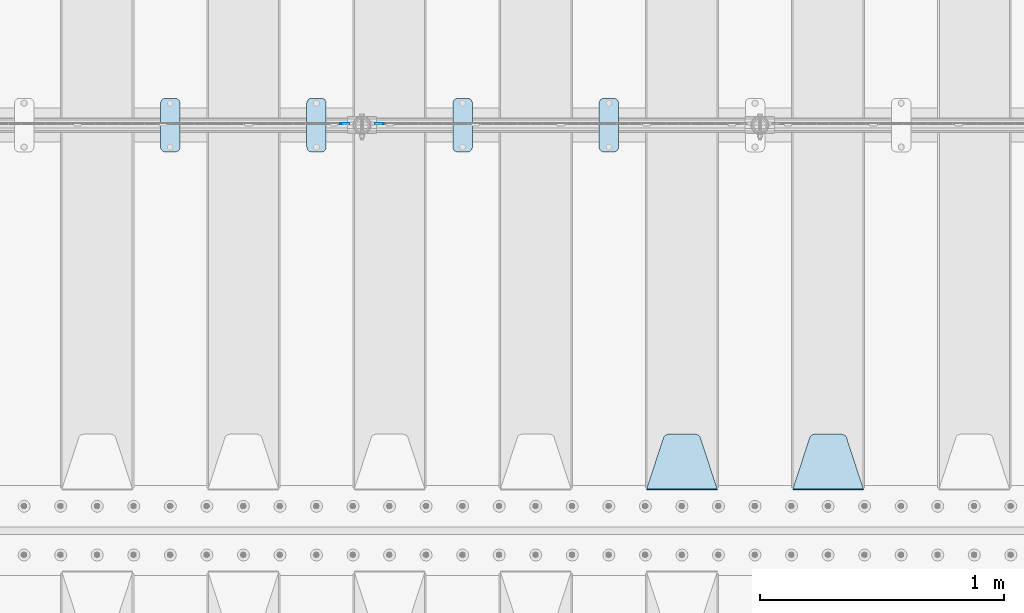
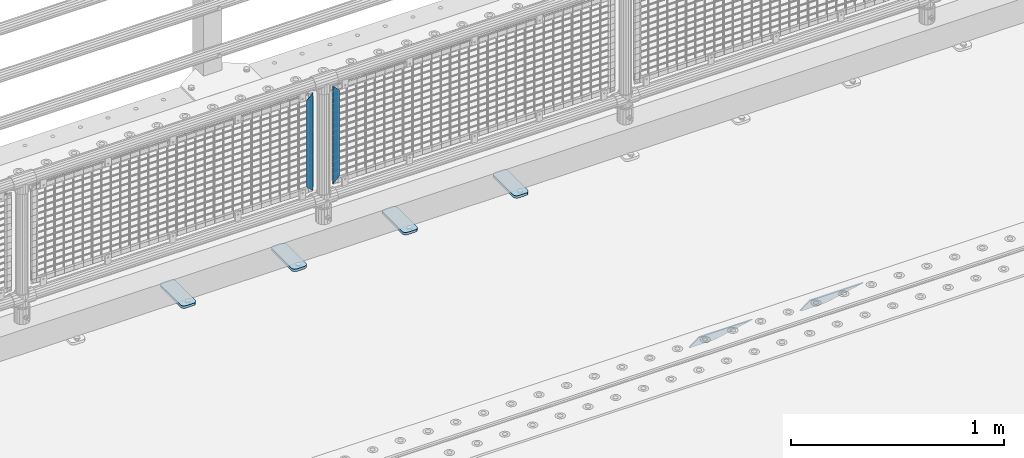
# One storey, part 202 of 242: 8 plates.
"""IFC2X3 building model written with IfcOpenShell, lengths in millimetres."""

from ifc_helpers import new_model, si_unit, frame, origin_with_axes, place, context, subcontext, project, spatial, faceted_brep, material, type_object, element, save


model = new_model("IFC2X3")

# Units and contexts
model_context = context("Model", 3, precision=1e-05, world=origin_with_axes())
body_context = subcontext(model_context, "Body", "Model", "MODEL_VIEW")
ifc_project = project(units=[si_unit("LENGTHUNIT", "METRE", prefix="MILLI"), si_unit("AREAUNIT", "SQUARE_METRE"), si_unit("VOLUMEUNIT", "CUBIC_METRE"), si_unit("MASSUNIT", "GRAM", prefix="KILO"), si_unit("TIMEUNIT", "SECOND"), si_unit("PLANEANGLEUNIT", "RADIAN"), si_unit("SOLIDANGLEUNIT", "STERADIAN"), si_unit("THERMODYNAMICTEMPERATUREUNIT", "DEGREE_CELSIUS"), si_unit("LUMINOUSINTENSITYUNIT", "LUMEN")], contexts=[model_context])

# Site, building, storey
site_placement = place(None, origin_with_axes())
site = spatial("IfcSite", under=ifc_project, at=site_placement, CompositionType="ELEMENT")
building_placement = place(site_placement, origin_with_axes())
building = spatial("IfcBuilding", under=site, at=building_placement, Name="Standard", CompositionType="ELEMENT")
storey_placement = place(building_placement, origin_with_axes())
storey = spatial("IfcBuildingStorey", under=building, at=storey_placement, Name="Undefined", CompositionType="ELEMENT", Elevation=0.0)

# Plates
ifc_material_1 = material(Name="Misc_Undefined")
plate_type_1 = type_object("IfcPlateType", PredefinedType="NOTDEFINED")
plate_1_placement = place(storey_placement, frame((-38474.490286459, -19329.5, 879.519963133601), z_axis=(-0.707008801899319, 0.0, -0.707204746899291), x_axis=(-0.707204746899296, 0.0, 0.707008801899313)))
element("IfcPlate", 1, at=plate_1_placement, inside=storey, type_object=plate_type_1, material=ifc_material_1, context=body_context, shape_type="Brep", body=[
    faceted_brep([(0.0, -1.50000000000364, 0.0), (-348.552185058597, -1.5, 348.655029296875), (-348.552185058597, 1.5, 348.655029296875), (-3.63797880709171e-12, 1.49999999999636, 0.0), (-348.544891357426, -1.5, 398.152496337891), (-348.544891357426, 1.5, 398.152496337891), (49.5043945312464, -1.5, 8.00355337560177e-11), (49.5043945312464, 1.5, 8.00355337560177e-11)], [[[0, 1, 2, 3]], [[1, 4, 5, 2]], [[4, 6, 7, 5]], [[6, 0, 3, 7]], [[5, 7, 3, 2]], [[6, 4, 1, 0]]]),
])
plate_2_placement = place(storey_placement, frame((-38651.5003125164, -19329.5, 879.52), z_axis=(0.707103624179499, 0.0, -0.707109938179501), x_axis=(0.707109938179508, 0.0, 0.707103624179492)))
element("IfcPlate", 2, at=plate_2_placement, inside=storey, type_object=plate_type_1, material=ifc_material_1, context=body_context, shape_type="Brep", body=[
    faceted_brep([(0.0, -1.50000000000364, 0.0), (-348.605163574222, -1.5, 348.602081298832), (-348.605163574222, 1.5, 348.602081298832), (-3.63797880709171e-12, 1.49999999999636, 0.0), (-348.605163574222, -1.5, 398.099334716801), (-348.605163574222, 1.5, 398.099334716801), (49.4976959228534, -1.5, -3.63797880709171e-12), (49.4976959228534, 1.5, -3.63797880709171e-12)], [[[0, 1, 2, 3]], [[1, 4, 5, 2]], [[4, 6, 7, 5]], [[6, 0, 3, 7]], [[5, 7, 3, 2]], [[6, 4, 1, 0]]]),
])
ifc_material_2 = material(Name="STEEL/S355J2")
plate_type_2 = type_object("IfcPlateType", PredefinedType="NOTDEFINED")
plate_3_placement = place(storey_placement, frame((-37590.0, -19225.5, 21.0199999999977), z_axis=(1.0, 0.0, 0.0), x_axis=(0.0, -1.0, 0.0)))
element("IfcPlate", 3, at=plate_3_placement, inside=storey, type_object=plate_type_2, material=ifc_material_2, context=body_context, shape_type="Brep", body=[
    faceted_brep([(0.0, -7.0, 20.0), (0.0, -7.0, 60.0), (0.0, 7.0, 60.0), (0.0, 7.0, 20.0), (0.384294391937146, -7.0, 63.9018064403208), (0.384294391937146, 7.0, 63.9018064403208), (1.52240934977453, -7.0, 67.6536686473009), (1.52240934977453, 7.0, 67.6536686473009), (3.37060775395003, -7.0, 71.1114046603907), (3.37060775395003, 7.0, 71.1114046603907), (5.8578643762703, -7.0, 74.1421356237297), (5.8578643762703, 7.0, 74.1421356237297), (8.88859533960931, -7.0, 76.62939224605), (8.88859533960931, 7.0, 76.62939224605), (12.3463313526991, -7.0, 78.4775906502255), (12.3463313526991, 7.0, 78.4775906502255), (16.0981935596792, -7.0, 79.6157056080629), (16.0981935596792, 7.0, 79.6157056080629), (20.0, -7.0, 80.0), (20.0, 7.0, 80.0), (200.0, -7.0, 80.0), (200.0, 7.0, 80.0), (203.901806440321, -7.0, 79.6157056080629), (203.901806440321, 7.0, 79.6157056080629), (207.653668647301, -7.0, 78.4775906502255), (207.653668647301, 7.0, 78.4775906502255), (211.111404660391, -7.0, 76.62939224605), (211.111404660391, 7.0, 76.62939224605), (214.14213562373, -7.0, 74.1421356237297), (214.14213562373, 7.0, 74.1421356237297), (216.62939224605, -7.0, 71.1114046603907), (216.62939224605, 7.0, 71.1114046603907), (218.477590650225, -7.0, 67.6536686473009), (218.477590650225, 7.0, 67.6536686473009), (219.615705608063, -7.0, 63.9018064403208), (219.615705608063, 7.0, 63.9018064403208), (220.0, -7.0, 60.0), (220.0, 7.0, 60.0), (220.0, -7.0, 20.0), (220.0, 7.0, 20.0), (219.615705608063, -7.0, 16.0981935596792), (219.615705608063, 7.0, 16.0981935596792), (218.477590650225, -7.0, 12.3463313526991), (218.477590650225, 7.0, 12.3463313526991), (216.62939224605, -7.0, 8.88859533960931), (216.62939224605, 7.0, 8.88859533960931), (214.14213562373, -7.0, 5.8578643762703), (214.14213562373, 7.0, 5.8578643762703), (211.111404660391, -7.0, 3.37060775395003), (211.111404660391, 7.0, 3.37060775395003), (207.653668647301, -7.0, 1.52240934977453), (207.653668647301, 7.0, 1.52240934977453), (203.901806440321, -7.0, 0.384294391937146), (203.901806440321, 7.0, 0.384294391937146), (200.0, -7.0, 0.0), (200.0, 7.0, 0.0), (20.0, -7.0, 0.0), (20.0, 7.0, 0.0), (16.0981935596792, -7.0, 0.384294391937146), (16.0981935596792, 7.0, 0.384294391937146), (12.3463313526991, -7.0, 1.52240934977453), (12.3463313526991, 7.0, 1.52240934977453), (8.88859533960931, -7.0, 3.37060775395003), (8.88859533960931, 7.0, 3.37060775395003), (5.8578643762703, -7.0, 5.8578643762703), (5.8578643762703, 7.0, 5.8578643762703), (3.37060775395003, -7.0, 8.88859533960931), (3.37060775395003, 7.0, 8.88859533960931), (1.52240934977453, -7.0, 12.3463313526991), (1.52240934977453, 7.0, 12.3463313526991), (0.384294391937146, -7.0, 16.0981935596792), (0.384294391937146, 7.0, 16.0981935596792)], [[[0, 1, 2, 3]], [[1, 4, 5, 2]], [[4, 6, 7, 5]], [[6, 8, 9, 7]], [[8, 10, 11, 9]], [[10, 12, 13, 11]], [[12, 14, 15, 13]], [[14, 16, 17, 15]], [[16, 18, 19, 17]], [[18, 20, 21, 19]], [[20, 22, 23, 21]], [[22, 24, 25, 23]], [[24, 26, 27, 25]], [[26, 28, 29, 27]], [[28, 30, 31, 29]], [[30, 32, 33, 31]], [[32, 34, 35, 33]], [[34, 36, 37, 35]], [[36, 38, 39, 37]], [[38, 40, 41, 39]], [[40, 42, 43, 41]], [[42, 44, 45, 43]], [[44, 46, 47, 45]], [[46, 48, 49, 47]], [[48, 50, 51, 49]], [[50, 52, 53, 51]], [[52, 54, 55, 53]], [[54, 56, 57, 55]], [[56, 58, 59, 57]], [[58, 60, 61, 59]], [[60, 62, 63, 61]], [[62, 64, 65, 63]], [[64, 66, 67, 65]], [[66, 68, 69, 67]], [[68, 70, 71, 69]], [[70, 0, 3, 71]], [[5, 7, 9, 11, 13, 15, 17, 19, 21, 23, 25, 27, 29, 31, 33, 35, 37, 39, 41, 43, 45, 47, 49, 51, 53, 55, 57, 59, 61, 63, 65, 67, 69, 71, 3, 2]], [[70, 68, 66, 64, 62, 60, 58, 56, 54, 52, 50, 48, 46, 44, 42, 40, 38, 36, 34, 32, 30, 28, 26, 24, 22, 20, 18, 16, 14, 12, 10, 8, 6, 4, 1, 0]]]),
])
plate_4_placement = place(storey_placement, frame((-38190.0, -19225.5, 21.0199999999977), z_axis=(1.0, 0.0, 0.0), x_axis=(0.0, -1.0, 0.0)))
element("IfcPlate", 4, at=plate_4_placement, inside=storey, type_object=plate_type_2, material=ifc_material_2, context=body_context, shape_type="Brep", body=[
    faceted_brep([(0.0, -7.0, 20.0), (0.0, -7.0, 60.0), (0.0, 7.0, 60.0), (0.0, 7.0, 20.0), (0.384294391937146, -7.0, 63.9018064403208), (0.384294391937146, 7.0, 63.9018064403208), (1.52240934977453, -7.0, 67.6536686473009), (1.52240934977453, 7.0, 67.6536686473009), (3.37060775395003, -7.0, 71.1114046603907), (3.37060775395003, 7.0, 71.1114046603907), (5.8578643762703, -7.0, 74.1421356237297), (5.8578643762703, 7.0, 74.1421356237297), (8.88859533960931, -7.0, 76.62939224605), (8.88859533960931, 7.0, 76.62939224605), (12.3463313526991, -7.0, 78.4775906502255), (12.3463313526991, 7.0, 78.4775906502255), (16.0981935596792, -7.0, 79.6157056080629), (16.0981935596792, 7.0, 79.6157056080629), (20.0, -7.0, 80.0), (20.0, 7.0, 80.0), (200.0, -7.0, 80.0), (200.0, 7.0, 80.0), (203.901806440321, -7.0, 79.6157056080629), (203.901806440321, 7.0, 79.6157056080629), (207.653668647301, -7.0, 78.4775906502255), (207.653668647301, 7.0, 78.4775906502255), (211.111404660391, -7.0, 76.62939224605), (211.111404660391, 7.0, 76.62939224605), (214.14213562373, -7.0, 74.1421356237297), (214.14213562373, 7.0, 74.1421356237297), (216.62939224605, -7.0, 71.1114046603907), (216.62939224605, 7.0, 71.1114046603907), (218.477590650225, -7.0, 67.6536686473009), (218.477590650225, 7.0, 67.6536686473009), (219.615705608063, -7.0, 63.9018064403208), (219.615705608063, 7.0, 63.9018064403208), (220.0, -7.0, 60.0), (220.0, 7.0, 60.0), (220.0, -7.0, 20.0), (220.0, 7.0, 20.0), (219.615705608063, -7.0, 16.0981935596792), (219.615705608063, 7.0, 16.0981935596792), (218.477590650225, -7.0, 12.3463313526991), (218.477590650225, 7.0, 12.3463313526991), (216.62939224605, -7.0, 8.88859533960931), (216.62939224605, 7.0, 8.88859533960931), (214.14213562373, -7.0, 5.8578643762703), (214.14213562373, 7.0, 5.8578643762703), (211.111404660391, -7.0, 3.37060775395003), (211.111404660391, 7.0, 3.37060775395003), (207.653668647301, -7.0, 1.52240934977453), (207.653668647301, 7.0, 1.52240934977453), (203.901806440321, -7.0, 0.384294391937146), (203.901806440321, 7.0, 0.384294391937146), (200.0, -7.0, 0.0), (200.0, 7.0, 0.0), (20.0, -7.0, 0.0), (20.0, 7.0, 0.0), (16.0981935596792, -7.0, 0.384294391937146), (16.0981935596792, 7.0, 0.384294391937146), (12.3463313526991, -7.0, 1.52240934977453), (12.3463313526991, 7.0, 1.52240934977453), (8.88859533960931, -7.0, 3.37060775395003), (8.88859533960931, 7.0, 3.37060775395003), (5.8578643762703, -7.0, 5.8578643762703), (5.8578643762703, 7.0, 5.8578643762703), (3.37060775395003, -7.0, 8.88859533960931), (3.37060775395003, 7.0, 8.88859533960931), (1.52240934977453, -7.0, 12.3463313526991), (1.52240934977453, 7.0, 12.3463313526991), (0.384294391937146, -7.0, 16.0981935596792), (0.384294391937146, 7.0, 16.0981935596792)], [[[0, 1, 2, 3]], [[1, 4, 5, 2]], [[4, 6, 7, 5]], [[6, 8, 9, 7]], [[8, 10, 11, 9]], [[10, 12, 13, 11]], [[12, 14, 15, 13]], [[14, 16, 17, 15]], [[16, 18, 19, 17]], [[18, 20, 21, 19]], [[20, 22, 23, 21]], [[22, 24, 25, 23]], [[24, 26, 27, 25]], [[26, 28, 29, 27]], [[28, 30, 31, 29]], [[30, 32, 33, 31]], [[32, 34, 35, 33]], [[34, 36, 37, 35]], [[36, 38, 39, 37]], [[38, 40, 41, 39]], [[40, 42, 43, 41]], [[42, 44, 45, 43]], [[44, 46, 47, 45]], [[46, 48, 49, 47]], [[48, 50, 51, 49]], [[50, 52, 53, 51]], [[52, 54, 55, 53]], [[54, 56, 57, 55]], [[56, 58, 59, 57]], [[58, 60, 61, 59]], [[60, 62, 63, 61]], [[62, 64, 65, 63]], [[64, 66, 67, 65]], [[66, 68, 69, 67]], [[68, 70, 71, 69]], [[70, 0, 3, 71]], [[5, 7, 9, 11, 13, 15, 17, 19, 21, 23, 25, 27, 29, 31, 33, 35, 37, 39, 41, 43, 45, 47, 49, 51, 53, 55, 57, 59, 61, 63, 65, 67, 69, 71, 3, 2]], [[70, 68, 66, 64, 62, 60, 58, 56, 54, 52, 50, 48, 46, 44, 42, 40, 38, 36, 34, 32, 30, 28, 26, 24, 22, 20, 18, 16, 14, 12, 10, 8, 6, 4, 1, 0]]]),
])
plate_5_placement = place(storey_placement, frame((-38790.0, -19225.5, 21.0199999999977), z_axis=(1.0, 0.0, 0.0), x_axis=(0.0, -1.0, 0.0)))
element("IfcPlate", 5, at=plate_5_placement, inside=storey, type_object=plate_type_2, material=ifc_material_2, context=body_context, shape_type="Brep", body=[
    faceted_brep([(0.0, -7.0, 20.0), (0.0, -7.0, 60.0), (0.0, 7.0, 60.0), (0.0, 7.0, 20.0), (0.384294391937146, -7.0, 63.9018064403208), (0.384294391937146, 7.0, 63.9018064403208), (1.52240934977453, -7.0, 67.6536686473009), (1.52240934977453, 7.0, 67.6536686473009), (3.37060775395003, -7.0, 71.1114046603907), (3.37060775395003, 7.0, 71.1114046603907), (5.8578643762703, -7.0, 74.1421356237297), (5.8578643762703, 7.0, 74.1421356237297), (8.88859533960931, -7.0, 76.62939224605), (8.88859533960931, 7.0, 76.62939224605), (12.3463313526991, -7.0, 78.4775906502255), (12.3463313526991, 7.0, 78.4775906502255), (16.0981935596792, -7.0, 79.6157056080629), (16.0981935596792, 7.0, 79.6157056080629), (20.0, -7.0, 80.0), (20.0, 7.0, 80.0), (200.0, -7.0, 80.0), (200.0, 7.0, 80.0), (203.901806440321, -7.0, 79.6157056080629), (203.901806440321, 7.0, 79.6157056080629), (207.653668647301, -7.0, 78.4775906502255), (207.653668647301, 7.0, 78.4775906502255), (211.111404660391, -7.0, 76.62939224605), (211.111404660391, 7.0, 76.62939224605), (214.14213562373, -7.0, 74.1421356237297), (214.14213562373, 7.0, 74.1421356237297), (216.62939224605, -7.0, 71.1114046603907), (216.62939224605, 7.0, 71.1114046603907), (218.477590650225, -7.0, 67.6536686473009), (218.477590650225, 7.0, 67.6536686473009), (219.615705608063, -7.0, 63.9018064403208), (219.615705608063, 7.0, 63.9018064403208), (220.0, -7.0, 60.0), (220.0, 7.0, 60.0), (220.0, -7.0, 20.0), (220.0, 7.0, 20.0), (219.615705608063, -7.0, 16.0981935596792), (219.615705608063, 7.0, 16.0981935596792), (218.477590650225, -7.0, 12.3463313526991), (218.477590650225, 7.0, 12.3463313526991), (216.62939224605, -7.0, 8.88859533960931), (216.62939224605, 7.0, 8.88859533960931), (214.14213562373, -7.0, 5.8578643762703), (214.14213562373, 7.0, 5.8578643762703), (211.111404660391, -7.0, 3.37060775395003), (211.111404660391, 7.0, 3.37060775395003), (207.653668647301, -7.0, 1.52240934977453), (207.653668647301, 7.0, 1.52240934977453), (203.901806440321, -7.0, 0.384294391937146), (203.901806440321, 7.0, 0.384294391937146), (200.0, -7.0, 0.0), (200.0, 7.0, 0.0), (20.0, -7.0, 0.0), (20.0, 7.0, 0.0), (16.0981935596792, -7.0, 0.384294391937146), (16.0981935596792, 7.0, 0.384294391937146), (12.3463313526991, -7.0, 1.52240934977453), (12.3463313526991, 7.0, 1.52240934977453), (8.88859533960931, -7.0, 3.37060775395003), (8.88859533960931, 7.0, 3.37060775395003), (5.8578643762703, -7.0, 5.8578643762703), (5.8578643762703, 7.0, 5.8578643762703), (3.37060775395003, -7.0, 8.88859533960931), (3.37060775395003, 7.0, 8.88859533960931), (1.52240934977453, -7.0, 12.3463313526991), (1.52240934977453, 7.0, 12.3463313526991), (0.384294391937146, -7.0, 16.0981935596792), (0.384294391937146, 7.0, 16.0981935596792)], [[[0, 1, 2, 3]], [[1, 4, 5, 2]], [[4, 6, 7, 5]], [[6, 8, 9, 7]], [[8, 10, 11, 9]], [[10, 12, 13, 11]], [[12, 14, 15, 13]], [[14, 16, 17, 15]], [[16, 18, 19, 17]], [[18, 20, 21, 19]], [[20, 22, 23, 21]], [[22, 24, 25, 23]], [[24, 26, 27, 25]], [[26, 28, 29, 27]], [[28, 30, 31, 29]], [[30, 32, 33, 31]], [[32, 34, 35, 33]], [[34, 36, 37, 35]], [[36, 38, 39, 37]], [[38, 40, 41, 39]], [[40, 42, 43, 41]], [[42, 44, 45, 43]], [[44, 46, 47, 45]], [[46, 48, 49, 47]], [[48, 50, 51, 49]], [[50, 52, 53, 51]], [[52, 54, 55, 53]], [[54, 56, 57, 55]], [[56, 58, 59, 57]], [[58, 60, 61, 59]], [[60, 62, 63, 61]], [[62, 64, 65, 63]], [[64, 66, 67, 65]], [[66, 68, 69, 67]], [[68, 70, 71, 69]], [[70, 0, 3, 71]], [[5, 7, 9, 11, 13, 15, 17, 19, 21, 23, 25, 27, 29, 31, 33, 35, 37, 39, 41, 43, 45, 47, 49, 51, 53, 55, 57, 59, 61, 63, 65, 67, 69, 71, 3, 2]], [[70, 68, 66, 64, 62, 60, 58, 56, 54, 52, 50, 48, 46, 44, 42, 40, 38, 36, 34, 32, 30, 28, 26, 24, 22, 20, 18, 16, 14, 12, 10, 8, 6, 4, 1, 0]]]),
])
plate_6_placement = place(storey_placement, frame((-39390.0, -19225.5, 21.0199999999977), z_axis=(1.0, 0.0, 0.0), x_axis=(0.0, -1.0, 0.0)))
element("IfcPlate", 6, at=plate_6_placement, inside=storey, type_object=plate_type_2, material=ifc_material_2, context=body_context, shape_type="Brep", body=[
    faceted_brep([(0.0, -7.0, 20.0), (0.0, -7.0, 60.0), (0.0, 7.0, 60.0), (0.0, 7.0, 20.0), (0.384294391937146, -7.0, 63.9018064403208), (0.384294391937146, 7.0, 63.9018064403208), (1.52240934977453, -7.0, 67.6536686473009), (1.52240934977453, 7.0, 67.6536686473009), (3.37060775395003, -7.0, 71.1114046603907), (3.37060775395003, 7.0, 71.1114046603907), (5.8578643762703, -7.0, 74.1421356237297), (5.8578643762703, 7.0, 74.1421356237297), (8.88859533960931, -7.0, 76.62939224605), (8.88859533960931, 7.0, 76.62939224605), (12.3463313526991, -7.0, 78.4775906502255), (12.3463313526991, 7.0, 78.4775906502255), (16.0981935596792, -7.0, 79.6157056080629), (16.0981935596792, 7.0, 79.6157056080629), (20.0, -7.0, 80.0), (20.0, 7.0, 80.0), (200.0, -7.0, 80.0), (200.0, 7.0, 80.0), (203.901806440321, -7.0, 79.6157056080629), (203.901806440321, 7.0, 79.6157056080629), (207.653668647301, -7.0, 78.4775906502255), (207.653668647301, 7.0, 78.4775906502255), (211.111404660391, -7.0, 76.62939224605), (211.111404660391, 7.0, 76.62939224605), (214.14213562373, -7.0, 74.1421356237297), (214.14213562373, 7.0, 74.1421356237297), (216.62939224605, -7.0, 71.1114046603907), (216.62939224605, 7.0, 71.1114046603907), (218.477590650225, -7.0, 67.6536686473009), (218.477590650225, 7.0, 67.6536686473009), (219.615705608063, -7.0, 63.9018064403208), (219.615705608063, 7.0, 63.9018064403208), (220.0, -7.0, 60.0), (220.0, 7.0, 60.0), (220.0, -7.0, 20.0), (220.0, 7.0, 20.0), (219.615705608063, -7.0, 16.0981935596792), (219.615705608063, 7.0, 16.0981935596792), (218.477590650225, -7.0, 12.3463313526991), (218.477590650225, 7.0, 12.3463313526991), (216.62939224605, -7.0, 8.88859533960931), (216.62939224605, 7.0, 8.88859533960931), (214.14213562373, -7.0, 5.8578643762703), (214.14213562373, 7.0, 5.8578643762703), (211.111404660391, -7.0, 3.37060775395003), (211.111404660391, 7.0, 3.37060775395003), (207.653668647301, -7.0, 1.52240934977453), (207.653668647301, 7.0, 1.52240934977453), (203.901806440321, -7.0, 0.384294391937146), (203.901806440321, 7.0, 0.384294391937146), (200.0, -7.0, 0.0), (200.0, 7.0, 0.0), (20.0, -7.0, 0.0), (20.0, 7.0, 0.0), (16.0981935596792, -7.0, 0.384294391937146), (16.0981935596792, 7.0, 0.384294391937146), (12.3463313526991, -7.0, 1.52240934977453), (12.3463313526991, 7.0, 1.52240934977453), (8.88859533960931, -7.0, 3.37060775395003), (8.88859533960931, 7.0, 3.37060775395003), (5.8578643762703, -7.0, 5.8578643762703), (5.8578643762703, 7.0, 5.8578643762703), (3.37060775395003, -7.0, 8.88859533960931), (3.37060775395003, 7.0, 8.88859533960931), (1.52240934977453, -7.0, 12.3463313526991), (1.52240934977453, 7.0, 12.3463313526991), (0.384294391937146, -7.0, 16.0981935596792), (0.384294391937146, 7.0, 16.0981935596792)], [[[0, 1, 2, 3]], [[1, 4, 5, 2]], [[4, 6, 7, 5]], [[6, 8, 9, 7]], [[8, 10, 11, 9]], [[10, 12, 13, 11]], [[12, 14, 15, 13]], [[14, 16, 17, 15]], [[16, 18, 19, 17]], [[18, 20, 21, 19]], [[20, 22, 23, 21]], [[22, 24, 25, 23]], [[24, 26, 27, 25]], [[26, 28, 29, 27]], [[28, 30, 31, 29]], [[30, 32, 33, 31]], [[32, 34, 35, 33]], [[34, 36, 37, 35]], [[36, 38, 39, 37]], [[38, 40, 41, 39]], [[40, 42, 43, 41]], [[42, 44, 45, 43]], [[44, 46, 47, 45]], [[46, 48, 49, 47]], [[48, 50, 51, 49]], [[50, 52, 53, 51]], [[52, 54, 55, 53]], [[54, 56, 57, 55]], [[56, 58, 59, 57]], [[58, 60, 61, 59]], [[60, 62, 63, 61]], [[62, 64, 65, 63]], [[64, 66, 67, 65]], [[66, 68, 69, 67]], [[68, 70, 71, 69]], [[70, 0, 3, 71]], [[5, 7, 9, 11, 13, 15, 17, 19, 21, 23, 25, 27, 29, 31, 33, 35, 37, 39, 41, 43, 45, 47, 49, 51, 53, 55, 57, 59, 61, 63, 65, 67, 69, 71, 3, 2]], [[70, 68, 66, 64, 62, 60, 58, 56, 54, 52, 50, 48, 46, 44, 42, 40, 38, 36, 34, 32, 30, 28, 26, 24, 22, 20, 18, 16, 14, 12, 10, 8, 6, 4, 1, 0]]]),
])
ifc_material_3 = material(Name="STEEL/S355N")
plate_type_3 = type_object("IfcPlateType", PredefinedType="NOTDEFINED")
plate_7_placement = place(storey_placement, frame((-36505.0, -20831.767766953, -1.76776695296758), z_axis=(0.0, 0.707106781186547, -0.707106781186548), x_axis=(-1.0, 0.0, 0.0)))
element("IfcPlate", 7, at=plate_7_placement, inside=storey, type_object=plate_type_3, material=ifc_material_3, context=body_context, shape_type="Brep", body=[
    faceted_brep([(0.0, -2.5, 0.0), (69.345504679477, -2.50000000000182, 300.171731424829), (69.345504679477, 2.5, 300.171731424829), (0.0, 2.5, 0.0), (70.9274061199576, -2.5, 304.897442415398), (70.9274061199576, 2.5, 304.897442415398), (73.3818627772307, -2.5, 309.234538108525), (73.3818627772307, 2.50000000000182, 309.234538108529), (76.6187032999551, -2.5, 313.023683126101), (76.6187032999551, 2.50000000000182, 313.023683126103), (80.5190132704993, -2.5, 316.12567259537), (80.5190132704993, 2.5, 316.12567259537), (84.9395038596849, -2.5, 318.426546230474), (84.9395038596849, 2.50000000000182, 318.426546230476), (89.7177759439219, -2.49999999999818, 319.841774983273), (89.7177759439219, 2.50000000000182, 319.841774983273), (94.678286292652, -2.5, 320.319366455076), (94.678286292652, 2.5, 320.319366455076), (195.321713707348, -2.5, 320.319366455076), (195.321713707348, 2.5, 320.319366455076), (200.282224056078, -2.5, 319.841774983272), (200.282224056078, 2.50000000000182, 319.841774983273), (205.060496140315, -2.5, 318.426546230474), (205.060496140315, 2.49999999999818, 318.426546230474), (209.480986729501, -2.49999999999818, 316.12567259537), (209.480986729501, 2.5, 316.12567259537), (213.381296700045, -2.5, 313.023683126101), (213.381296700045, 2.49999999999818, 313.023683126101), (216.618137222769, -2.5, 309.234538108525), (216.618137222769, 2.5, 309.234538108523), (219.072593880042, -2.49999999999818, 304.897442415398), (219.072593880042, 2.50000000000182, 304.897442415398), (220.654495320523, -2.50000000000182, 300.171731424829), (220.654495320523, 2.5, 300.171731424829), (290.0, -2.5, 0.0), (290.0, 2.5, -1.81898940354586e-12)], [[[0, 1, 2, 3]], [[1, 4, 5, 2]], [[4, 6, 7, 5]], [[6, 8, 9, 7]], [[8, 10, 11, 9]], [[10, 12, 13, 11]], [[12, 14, 15, 13]], [[14, 16, 17, 15]], [[16, 18, 19, 17]], [[18, 20, 21, 19]], [[20, 22, 23, 21]], [[22, 24, 25, 23]], [[24, 26, 27, 25]], [[26, 28, 29, 27]], [[28, 30, 31, 29]], [[30, 32, 33, 31]], [[32, 34, 35, 33]], [[34, 0, 3, 35]], [[5, 7, 9, 11, 13, 15, 17, 19, 21, 23, 25, 27, 29, 31, 33, 35, 3, 2]], [[34, 32, 30, 28, 26, 24, 22, 20, 18, 16, 14, 12, 10, 8, 6, 4, 1, 0]]]),
])
plate_8_placement = place(storey_placement, frame((-37105.0, -20831.767766953, -1.76776695296758), z_axis=(0.0, 0.707106781186547, -0.707106781186548), x_axis=(-1.0, 0.0, 0.0)))
element("IfcPlate", 8, at=plate_8_placement, inside=storey, type_object=plate_type_3, material=ifc_material_3, context=body_context, shape_type="Brep", body=[
    faceted_brep([(0.0, -2.5, 0.0), (69.345504679477, -2.50000000000182, 300.171731424829), (69.345504679477, 2.5, 300.171731424829), (0.0, 2.5, 0.0), (70.9274061199576, -2.5, 304.897442415398), (70.9274061199576, 2.5, 304.897442415398), (73.3818627772307, -2.5, 309.234538108525), (73.3818627772307, 2.50000000000182, 309.234538108529), (76.6187032999551, -2.5, 313.023683126101), (76.6187032999551, 2.50000000000182, 313.023683126103), (80.5190132704993, -2.5, 316.12567259537), (80.5190132704993, 2.5, 316.12567259537), (84.9395038596849, -2.5, 318.426546230474), (84.9395038596849, 2.50000000000182, 318.426546230476), (89.7177759439219, -2.49999999999818, 319.841774983273), (89.7177759439219, 2.50000000000182, 319.841774983273), (94.678286292652, -2.5, 320.319366455076), (94.678286292652, 2.5, 320.319366455076), (195.321713707348, -2.5, 320.319366455076), (195.321713707348, 2.5, 320.319366455076), (200.282224056078, -2.5, 319.841774983272), (200.282224056078, 2.50000000000182, 319.841774983273), (205.060496140315, -2.5, 318.426546230474), (205.060496140315, 2.49999999999818, 318.426546230474), (209.480986729501, -2.49999999999818, 316.12567259537), (209.480986729501, 2.5, 316.12567259537), (213.381296700045, -2.5, 313.023683126101), (213.381296700045, 2.49999999999818, 313.023683126101), (216.618137222769, -2.5, 309.234538108525), (216.618137222769, 2.5, 309.234538108523), (219.072593880042, -2.49999999999818, 304.897442415398), (219.072593880042, 2.50000000000182, 304.897442415398), (220.654495320523, -2.50000000000182, 300.171731424829), (220.654495320523, 2.5, 300.171731424829), (290.0, -2.5, 0.0), (290.0, 2.5, -1.81898940354586e-12)], [[[0, 1, 2, 3]], [[1, 4, 5, 2]], [[4, 6, 7, 5]], [[6, 8, 9, 7]], [[8, 10, 11, 9]], [[10, 12, 13, 11]], [[12, 14, 15, 13]], [[14, 16, 17, 15]], [[16, 18, 19, 17]], [[18, 20, 21, 19]], [[20, 22, 23, 21]], [[22, 24, 25, 23]], [[24, 26, 27, 25]], [[26, 28, 29, 27]], [[28, 30, 31, 29]], [[30, 32, 33, 31]], [[32, 34, 35, 33]], [[34, 0, 3, 35]], [[5, 7, 9, 11, 13, 15, 17, 19, 21, 23, 25, 27, 29, 31, 33, 35, 3, 2]], [[34, 32, 30, 28, 26, 24, 22, 20, 18, 16, 14, 12, 10, 8, 6, 4, 1, 0]]]),
])

save(model, "model.ifc")
